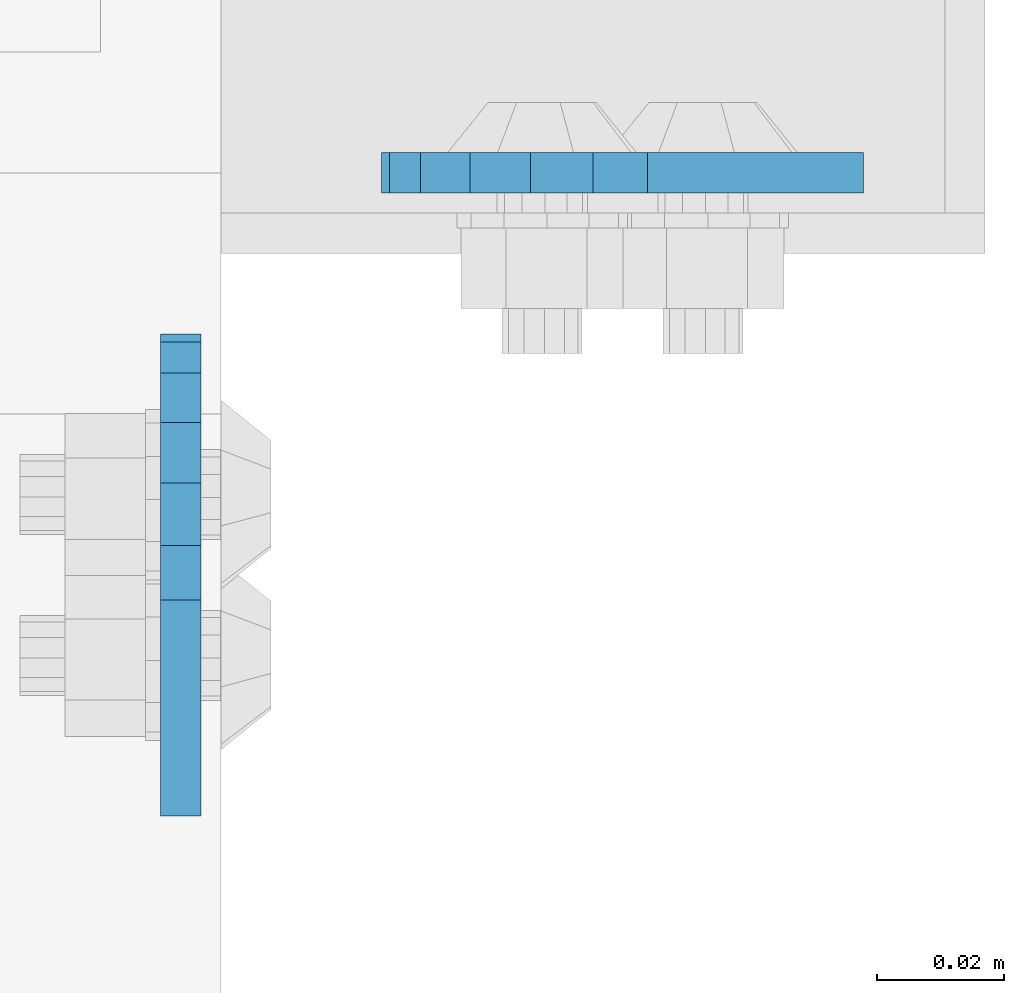
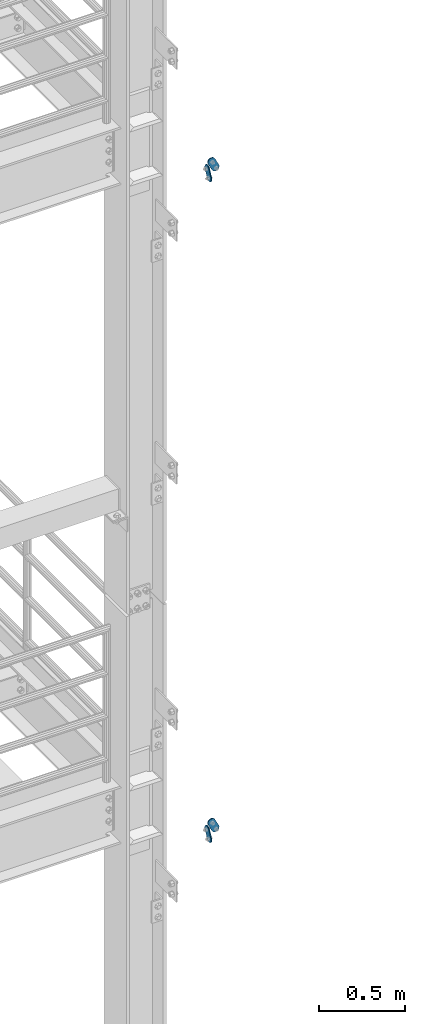
# One storey, part 1518 of 1876: 4 plates, 4 elements without a shape of their own.
"""IFC2X3 building model written with IfcOpenShell, lengths in millimetres."""

from ifc_helpers import new_model, si_unit, frame, origin_with_axes, place, context, subcontext, project, spatial, faceted_brep, material, type_object, element, aggregate, save


model = new_model("IFC2X3")

# Units and contexts
model_context = context("Model", 3, precision=1e-05, world=origin_with_axes())
body_context = subcontext(model_context, "Body", "Model", "MODEL_VIEW")
ifc_project = project(units=[si_unit("LENGTHUNIT", "METRE", prefix="MILLI"), si_unit("AREAUNIT", "SQUARE_METRE"), si_unit("VOLUMEUNIT", "CUBIC_METRE"), si_unit("MASSUNIT", "GRAM", prefix="KILO"), si_unit("TIMEUNIT", "SECOND"), si_unit("PLANEANGLEUNIT", "RADIAN"), si_unit("SOLIDANGLEUNIT", "STERADIAN"), si_unit("THERMODYNAMICTEMPERATUREUNIT", "DEGREE_CELSIUS"), si_unit("LUMINOUSINTENSITYUNIT", "LUMEN")], contexts=[model_context])

# Site, building, storey
site_placement = place(None, origin_with_axes())
site = spatial("IfcSite", under=ifc_project, at=site_placement, CompositionType="ELEMENT")
building_placement = place(site_placement, origin_with_axes())
building = spatial("IfcBuilding", under=site, at=building_placement, Name="Undefined", CompositionType="ELEMENT")
storey_placement = place(building_placement, origin_with_axes())
storey = spatial("IfcBuildingStorey", under=building, at=storey_placement, Name="Undefined", CompositionType="ELEMENT", Elevation=0.0)

# Assembly, plate
assembly_1_placement = place(storey_placement, origin_with_axes())
assembly_1 = element("IfcElementAssembly", 1, at=assembly_1_placement, inside=storey, Name="PLATE", AssemblyPlace="NOTDEFINED", PredefinedType="RIGID_FRAME")
ifc_material = material(Name="STEEL/A36")
plate_type = type_object("IfcPlateType", PredefinedType="NOTDEFINED")
plate_1_placement = place(assembly_1_placement, frame((7974.16265160786, -7404.08879451656, 17725.1776774809), z_axis=(-0.894427191199917, 1.49999996210681e-08, -0.447213595099955), x_axis=(0.447213595099955, -6.99999707257281e-09, -0.894427191199917)))
plate_1 = element("IfcPlate", 2, at=plate_1_placement, type_object=plate_type, material=ifc_material, Name="PLATE", context=body_context, shape_type="Brep", body=[
    faceted_brep([(-8.59611645864788e-07, -3.17499999999654, 25.3999987589127), (1.93345873884391, -3.17499999999382, 35.1201580589886), (1.93345873884391, 3.17500000000564, 35.1201580589886), (-8.59611645864788e-07, 3.17500000000382, 25.3999987589132), (7.43948648259902, -3.17499999999109, 43.3605112870105), (7.43948648259902, 3.17500000000928, 43.3605112870105), (15.6798395242777, -3.17499999998654, 48.8665393096448), (15.6798395242777, 3.17500000001382, 48.8665393096448), (25.3999987589095, -3.17499999998199, 50.7999992370592), (25.3999987589095, 3.17500000001837, 50.7999992370592), (82.196130752618, -3.17499999998381, 50.7999992370605), (82.196130752618, 3.17500000001655, 50.7999992370642), (91.9162897887145, -3.17499999997926, 48.8665393918873), (91.9162897887145, 3.1750000000211, 48.8665393918909), (100.156642725027, -3.17499999997472, 43.3605115909359), (100.156642725027, 3.17500000002565, 43.3605115909395), (105.662670525982, -3.17499999997108, 35.1201586546285), (105.662670525986, 3.17500000002929, 35.1201586546358), (107.596130371159, -3.17499999996744, 25.3999996185757), (107.596130371159, 3.17500000003292, 25.3999996185794), (105.662670525981, -3.17499999996471, 15.6798405824902), (105.662670525981, 3.17500000003565, 15.6798405824939), (100.156642725024, -3.17499999996471, 7.43948764618654), (100.156642725025, 3.17500000003565, 7.43948764619017), (91.9162897887127, -3.17499999996562, 1.93345984522784), (91.9162897887127, 3.17500000003474, 1.93345984523148), (82.196130752618, -3.17499999996835, 4.54747350886464e-11), (82.196130752618, 3.1750000000311, 4.91127138957381e-11), (25.399998758905, -3.17499999999018, -8.64019966684282e-12), (25.399998758905, 3.17500000001019, -8.64019966684282e-12), (15.679839921364, -3.17499999999382, 1.9334597629304), (15.679839921364, 3.17500000000655, 1.9334597629304), (7.43948709043525, -3.17499999999654, 7.43948734220839), (7.43948709043525, 3.17500000000382, 7.43948734220885), (1.93345923228208, -3.17499999999654, 15.6798399868012), (1.93345923228208, 3.17500000000291, 15.6798399868012)], [[[0, 1, 2, 3]], [[1, 4, 5, 2]], [[4, 6, 7, 5]], [[6, 8, 9, 7]], [[8, 10, 11, 9]], [[10, 12, 13, 11]], [[12, 14, 15, 13]], [[14, 16, 17, 15]], [[16, 18, 19, 17]], [[18, 20, 21, 19]], [[20, 22, 23, 21]], [[22, 24, 25, 23]], [[24, 26, 27, 25]], [[26, 28, 29, 27]], [[28, 30, 31, 29]], [[30, 32, 33, 31]], [[32, 34, 35, 33]], [[34, 0, 3, 35]], [[5, 7, 9, 11, 13, 15, 17, 19, 21, 23, 25, 27, 29, 31, 33, 35, 3, 2]], [[34, 32, 30, 28, 26, 24, 22, 20, 18, 16, 14, 12, 10, 8, 6, 4, 1, 0]]]),
])
aggregate(assembly_1, [plate_1])

assembly_2_placement = place(storey_placement, origin_with_axes())
assembly_2 = element("IfcElementAssembly", 3, at=assembly_2_placement, inside=storey, Name="PLATE", AssemblyPlace="NOTDEFINED", PredefinedType="RIGID_FRAME")
plate_2_placement = place(assembly_2_placement, frame((7974.16265162523, -7404.08879451656, 13038.8776774809), z_axis=(-0.894427191199917, 1.49999996210681e-08, -0.447213595099955), x_axis=(0.447213595099955, -6.99999707257281e-09, -0.894427191199917)))
plate_2 = element("IfcPlate", 4, at=plate_2_placement, type_object=plate_type, material=ifc_material, Name="PLATE", context=body_context, shape_type="Brep", body=[
    faceted_brep([(-8.59611645864788e-07, -3.17499999999654, 25.3999987589127), (1.93345873884391, -3.17499999999382, 35.1201580589886), (1.93345873884391, 3.17500000000564, 35.1201580589886), (-8.59611645864788e-07, 3.17500000000382, 25.3999987589132), (7.43948648259902, -3.17499999999109, 43.3605112870105), (7.43948648259902, 3.17500000000928, 43.3605112870105), (15.6798395242777, -3.17499999998654, 48.8665393096448), (15.6798395242777, 3.17500000001382, 48.8665393096448), (25.3999987589095, -3.17499999998199, 50.7999992370592), (25.3999987589095, 3.17500000001837, 50.7999992370592), (82.196130752618, -3.17499999998381, 50.7999992370605), (82.196130752618, 3.17500000001655, 50.7999992370642), (91.9162897887145, -3.17499999997926, 48.8665393918873), (91.9162897887145, 3.1750000000211, 48.8665393918909), (100.156642725027, -3.17499999997472, 43.3605115909359), (100.156642725027, 3.17500000002565, 43.3605115909395), (105.662670525982, -3.17499999997108, 35.1201586546285), (105.662670525986, 3.17500000002929, 35.1201586546358), (107.596130371159, -3.17499999996744, 25.3999996185757), (107.596130371159, 3.17500000003292, 25.3999996185794), (105.662670525981, -3.17499999996471, 15.6798405824902), (105.662670525981, 3.17500000003565, 15.6798405824939), (100.156642725024, -3.17499999996471, 7.43948764618654), (100.156642725025, 3.17500000003565, 7.43948764619017), (91.9162897887127, -3.17499999996562, 1.93345984522784), (91.9162897887127, 3.17500000003474, 1.93345984523148), (82.196130752618, -3.17499999996835, 4.54747350886464e-11), (82.196130752618, 3.1750000000311, 4.91127138957381e-11), (25.399998758905, -3.17499999999018, -8.64019966684282e-12), (25.399998758905, 3.17500000001019, -8.64019966684282e-12), (15.679839921364, -3.17499999999382, 1.9334597629304), (15.679839921364, 3.17500000000655, 1.9334597629304), (7.43948709043525, -3.17499999999654, 7.43948734220839), (7.43948709043525, 3.17500000000382, 7.43948734220885), (1.93345923228208, -3.17499999999654, 15.6798399868012), (1.93345923228208, 3.17500000000291, 15.6798399868012)], [[[0, 1, 2, 3]], [[1, 4, 5, 2]], [[4, 6, 7, 5]], [[6, 8, 9, 7]], [[8, 10, 11, 9]], [[10, 12, 13, 11]], [[12, 14, 15, 13]], [[14, 16, 17, 15]], [[16, 18, 19, 17]], [[18, 20, 21, 19]], [[20, 22, 23, 21]], [[22, 24, 25, 23]], [[24, 26, 27, 25]], [[26, 28, 29, 27]], [[28, 30, 31, 29]], [[30, 32, 33, 31]], [[32, 34, 35, 33]], [[34, 0, 3, 35]], [[5, 7, 9, 11, 13, 15, 17, 19, 21, 23, 25, 27, 29, 31, 33, 35, 3, 2]], [[34, 32, 30, 28, 26, 24, 22, 20, 18, 16, 14, 12, 10, 8, 6, 4, 1, 0]]]),
])
aggregate(assembly_2, [plate_2])

assembly_3_placement = place(storey_placement, origin_with_axes())
assembly_3 = element("IfcElementAssembly", 5, at=assembly_3_placement, inside=storey, Name="PLATE", AssemblyPlace="NOTDEFINED", PredefinedType="RIGID_FRAME")
plate_3_placement = place(assembly_3_placement, frame((7905.73879597858, -7466.25922341129, 17725.1776774809), z_axis=(0.0, 0.894427191199917, -0.447213595099955), x_axis=(0.0, -0.447213595099955, -0.894427191199917)))
plate_3 = element("IfcPlate", 6, at=plate_3_placement, type_object=plate_type, material=ifc_material, Name="PLATE", context=body_context, shape_type="Brep", body=[
    faceted_brep([(-8.59611645864788e-07, -3.17499999999654, 25.3999987589127), (1.93345873884391, -3.17499999999382, 35.1201580589886), (1.93345873884391, 3.17500000000564, 35.1201580589886), (-8.59611645864788e-07, 3.17500000000382, 25.3999987589132), (7.43948648259902, -3.17499999999109, 43.3605112870105), (7.43948648259902, 3.17500000000928, 43.3605112870105), (15.6798395242777, -3.17499999998654, 48.8665393096448), (15.6798395242777, 3.17500000001382, 48.8665393096448), (25.3999987589095, -3.17499999998199, 50.7999992370592), (25.3999987589095, 3.17500000001837, 50.7999992370592), (82.196130752618, -3.17499999998381, 50.7999992370605), (82.196130752618, 3.17500000001655, 50.7999992370642), (91.9162897887145, -3.17499999997926, 48.8665393918873), (91.9162897887145, 3.1750000000211, 48.8665393918909), (100.156642725027, -3.17499999997472, 43.3605115909359), (100.156642725027, 3.17500000002565, 43.3605115909395), (105.662670525982, -3.17499999997108, 35.1201586546285), (105.662670525986, 3.17500000002929, 35.1201586546358), (107.596130371159, -3.17499999996744, 25.3999996185757), (107.596130371159, 3.17500000003292, 25.3999996185794), (105.662670525981, -3.17499999996471, 15.6798405824902), (105.662670525981, 3.17500000003565, 15.6798405824939), (100.156642725024, -3.17499999996471, 7.43948764618654), (100.156642725025, 3.17500000003565, 7.43948764619017), (91.9162897887127, -3.17499999996562, 1.93345984522784), (91.9162897887127, 3.17500000003474, 1.93345984523148), (82.196130752618, -3.17499999996835, 4.54747350886464e-11), (82.196130752618, 3.1750000000311, 4.91127138957381e-11), (25.399998758905, -3.17499999999018, -8.64019966684282e-12), (25.399998758905, 3.17500000001019, -8.64019966684282e-12), (15.679839921364, -3.17499999999382, 1.9334597629304), (15.679839921364, 3.17500000000655, 1.9334597629304), (7.43948709043525, -3.17499999999654, 7.43948734220839), (7.43948709043525, 3.17500000000382, 7.43948734220885), (1.93345923228208, -3.17499999999654, 15.6798399868012), (1.93345923228208, 3.17500000000291, 15.6798399868012)], [[[0, 1, 2, 3]], [[1, 4, 5, 2]], [[4, 6, 7, 5]], [[6, 8, 9, 7]], [[8, 10, 11, 9]], [[10, 12, 13, 11]], [[12, 14, 15, 13]], [[14, 16, 17, 15]], [[16, 18, 19, 17]], [[18, 20, 21, 19]], [[20, 22, 23, 21]], [[22, 24, 25, 23]], [[24, 26, 27, 25]], [[26, 28, 29, 27]], [[28, 30, 31, 29]], [[30, 32, 33, 31]], [[32, 34, 35, 33]], [[34, 0, 3, 35]], [[5, 7, 9, 11, 13, 15, 17, 19, 21, 23, 25, 27, 29, 31, 33, 35, 3, 2]], [[34, 32, 30, 28, 26, 24, 22, 20, 18, 16, 14, 12, 10, 8, 6, 4, 1, 0]]]),
])
aggregate(assembly_3, [plate_3])

assembly_4_placement = place(storey_placement, origin_with_axes())
assembly_4 = element("IfcElementAssembly", 7, at=assembly_4_placement, inside=storey, Name="PLATE", AssemblyPlace="NOTDEFINED", PredefinedType="RIGID_FRAME")
plate_4_placement = place(assembly_4_placement, frame((7905.73879597858, -7466.25922341129, 13038.8776774809), z_axis=(0.0, 0.894427191199917, -0.447213595099955), x_axis=(0.0, -0.447213595099955, -0.894427191199917)))
plate_4 = element("IfcPlate", 8, at=plate_4_placement, type_object=plate_type, material=ifc_material, Name="PLATE", context=body_context, shape_type="Brep", body=[
    faceted_brep([(-8.59611645864788e-07, -3.17499999999654, 25.3999987589127), (1.93345873884391, -3.17499999999382, 35.1201580589886), (1.93345873884391, 3.17500000000564, 35.1201580589886), (-8.59611645864788e-07, 3.17500000000382, 25.3999987589132), (7.43948648259902, -3.17499999999109, 43.3605112870105), (7.43948648259902, 3.17500000000928, 43.3605112870105), (15.6798395242777, -3.17499999998654, 48.8665393096448), (15.6798395242777, 3.17500000001382, 48.8665393096448), (25.3999987589095, -3.17499999998199, 50.7999992370592), (25.3999987589095, 3.17500000001837, 50.7999992370592), (82.196130752618, -3.17499999998381, 50.7999992370605), (82.196130752618, 3.17500000001655, 50.7999992370642), (91.9162897887145, -3.17499999997926, 48.8665393918873), (91.9162897887145, 3.1750000000211, 48.8665393918909), (100.156642725027, -3.17499999997472, 43.3605115909359), (100.156642725027, 3.17500000002565, 43.3605115909395), (105.662670525982, -3.17499999997108, 35.1201586546285), (105.662670525986, 3.17500000002929, 35.1201586546358), (107.596130371159, -3.17499999996744, 25.3999996185757), (107.596130371159, 3.17500000003292, 25.3999996185794), (105.662670525981, -3.17499999996471, 15.6798405824902), (105.662670525981, 3.17500000003565, 15.6798405824939), (100.156642725024, -3.17499999996471, 7.43948764618654), (100.156642725025, 3.17500000003565, 7.43948764619017), (91.9162897887127, -3.17499999996562, 1.93345984522784), (91.9162897887127, 3.17500000003474, 1.93345984523148), (82.196130752618, -3.17499999996835, 4.54747350886464e-11), (82.196130752618, 3.1750000000311, 4.91127138957381e-11), (25.399998758905, -3.17499999999018, -8.64019966684282e-12), (25.399998758905, 3.17500000001019, -8.64019966684282e-12), (15.679839921364, -3.17499999999382, 1.9334597629304), (15.679839921364, 3.17500000000655, 1.9334597629304), (7.43948709043525, -3.17499999999654, 7.43948734220839), (7.43948709043525, 3.17500000000382, 7.43948734220885), (1.93345923228208, -3.17499999999654, 15.6798399868012), (1.93345923228208, 3.17500000000291, 15.6798399868012)], [[[0, 1, 2, 3]], [[1, 4, 5, 2]], [[4, 6, 7, 5]], [[6, 8, 9, 7]], [[8, 10, 11, 9]], [[10, 12, 13, 11]], [[12, 14, 15, 13]], [[14, 16, 17, 15]], [[16, 18, 19, 17]], [[18, 20, 21, 19]], [[20, 22, 23, 21]], [[22, 24, 25, 23]], [[24, 26, 27, 25]], [[26, 28, 29, 27]], [[28, 30, 31, 29]], [[30, 32, 33, 31]], [[32, 34, 35, 33]], [[34, 0, 3, 35]], [[5, 7, 9, 11, 13, 15, 17, 19, 21, 23, 25, 27, 29, 31, 33, 35, 3, 2]], [[34, 32, 30, 28, 26, 24, 22, 20, 18, 16, 14, 12, 10, 8, 6, 4, 1, 0]]]),
])
aggregate(assembly_4, [plate_4])

save(model, "model.ifc")
